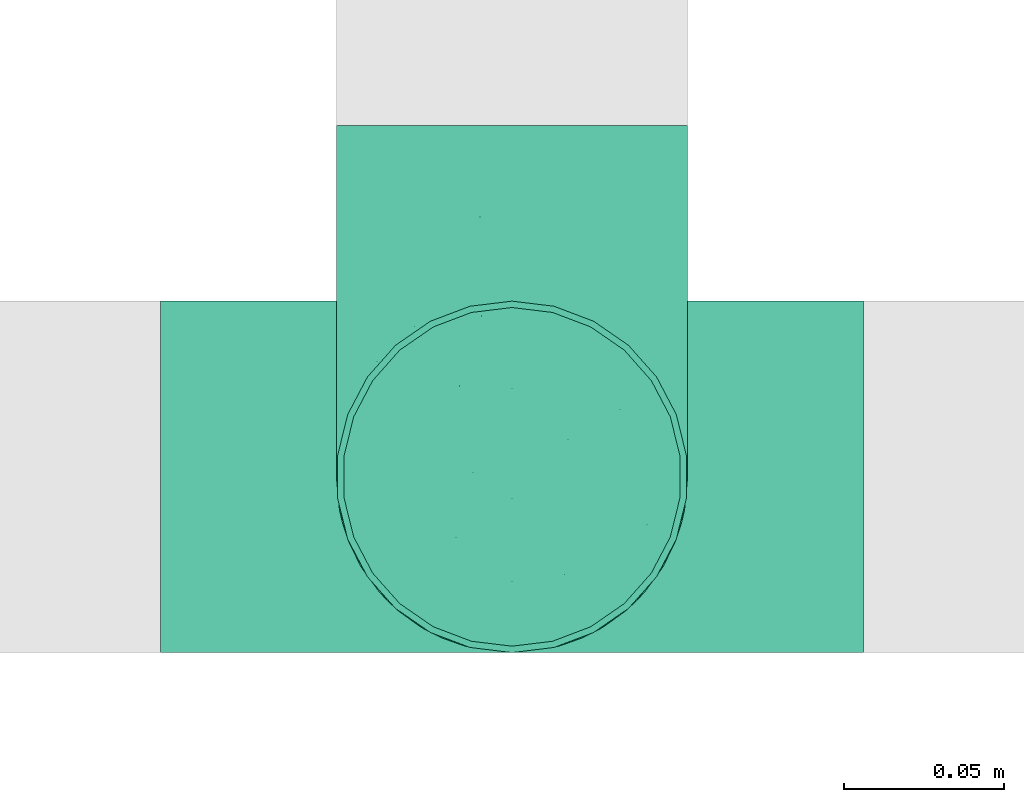
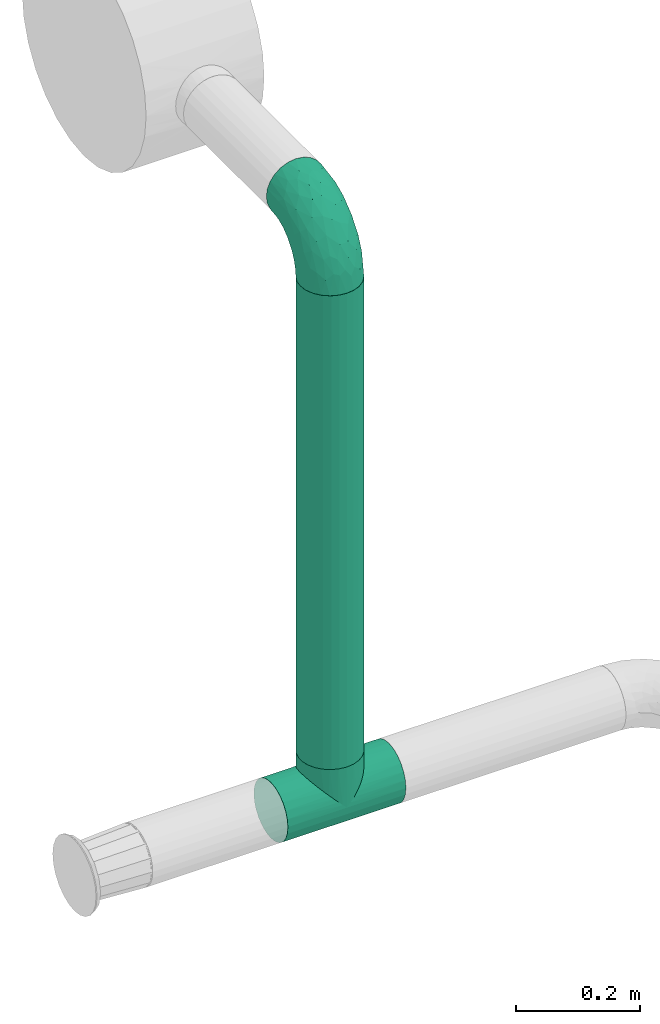
# One storey, part 85 of 103: 2 flow fittings, 1 flow segment.
"""IFC2X3 building model written with IfcOpenShell, lengths in millimetres."""

from ifc_helpers import new_model, entity, si_unit, converted_unit, derived_unit, direction, frame, origin_with_axes, origin_2d_with_axis, place, context, subcontext, project, spatial, hollow_circle, extrude, open_shell, surface_model, source, transform, mapped, material, layer, layer_set, layer_usage, type_object, element, save


model = new_model("IFC2X3")

# Units and contexts
model_context = context("Model", 3, precision=1e-05, world=origin_with_axes(), true_north=direction((0.0, 1.0)))
body_context = subcontext(model_context, "Body", "Model", "MODEL_VIEW")
ifc_project = project(units=[si_unit("AREAUNIT", "SQUARE_METRE"), si_unit("VOLUMEUNIT", "CUBIC_METRE", prefix="DECI"), si_unit("TIMEUNIT", "SECOND"), si_unit("THERMODYNAMICTEMPERATUREUNIT", "DEGREE_CELSIUS"), si_unit("PRESSUREUNIT", "PASCAL"), si_unit("MASSUNIT", "GRAM", prefix="KILO"), si_unit("LENGTHUNIT", "METRE", prefix="MILLI"), si_unit("POWERUNIT", "WATT"), si_unit("ELECTRICCURRENTUNIT", "AMPERE"), si_unit("ELECTRICVOLTAGEUNIT", "VOLT"), derived_unit("VOLUMETRICFLOWRATEUNIT", [(si_unit("VOLUMEUNIT", "CUBIC_METRE", prefix="DECI"), 1), (si_unit("TIMEUNIT", "SECOND"), -1)]), derived_unit("LINEARVELOCITYUNIT", [(si_unit("LENGTHUNIT", "METRE"), 1), (si_unit("TIMEUNIT", "SECOND"), -1)]), derived_unit("MASSDENSITYUNIT", [(si_unit("MASSUNIT", "GRAM", prefix="KILO"), 1), (si_unit("VOLUMEUNIT", "CUBIC_METRE"), -1)]), converted_unit("PLANEANGLEUNIT", "DEGREE", entity("IfcRatioMeasure", 0.01745), si_unit("PLANEANGLEUNIT", "RADIAN"), dimensions=[0, 0, 0, 0, 0, 0, 0])], contexts=[model_context])

# Site, building, storey
site_placement = place(None, origin_with_axes())
site = spatial("IfcSite", under=ifc_project, at=site_placement, CompositionType="ELEMENT")
building_placement = place(site_placement, origin_with_axes())
building = spatial("IfcBuilding", under=site, at=building_placement, Name="mc-building", CompositionType="ELEMENT")
storey_placement = place(building_placement, frame((0.0, 0.0, 5900.0), z_axis=(0.0, 0.0, 1.0), x_axis=(1.0, 0.0, 0.0)))
storey = spatial("IfcBuildingStorey", under=building, at=storey_placement, Name="3. Korrus", CompositionType="ELEMENT", Elevation=5900.0)

# Flow fitting
duct_fitting_type_1 = type_object("IfcDuctFittingType", PredefinedType="JUNCTION")
shared_shape_1 = source(origin_with_axes(), body_context, "Body", "SurfaceModel", [
    surface_model("IfcShellBasedSurfaceModel", [(0.0, -80.0, -55.0), (14.23505, -80.0, -53.12592), (-14.23505, -80.0, -53.12592), (-53.12592, -80.0, 14.23505), (-27.5, -80.0, -47.63139), (-47.63139, -80.0, -27.5), (-38.89087, -80.0, -38.89087), (55.0, -80.0, 0.0), (53.12592, -80.0, 14.23505), (38.89087, -80.0, -38.89087), (27.5, -80.0, -47.63139), (53.12592, -80.0, -14.23505), (47.63139, -80.0, -27.5), (-53.12592, -80.0, -14.23505), (-47.63139, -80.0, 27.5), (-38.89087, -80.0, 38.89087), (14.23505, -80.0, 53.12592), (-27.5, -80.0, 47.63139), (-14.23505, -80.0, 53.12592), (47.63139, -80.0, 27.5), (38.89087, -80.0, 38.89087), (27.5, -80.0, 47.63139), (0.0, -80.0, 55.0), (-55.0, -80.0, 0.0), (0.0, 0.0, 55.0), (-7.4066, -7.4066, 54.49901), (-14.74521, -14.74521, 52.98659), (-21.93978, -21.93978, 50.43457), (-28.89905, -28.89905, 46.79578), (-35.50357, -35.50357, 42.00591), (-41.58668, -41.58668, 35.99373), (-46.92319, -46.92319, 28.69171), (-51.19777, -51.19777, 20.0945), (-50.37866, -80.0, 20.86752), (-54.01174, -54.01174, 10.37938), (-55.0, -55.0, 0.0), (-54.06296, -80.0, 7.11752), (-54.01174, -54.01174, -10.37938), (-51.19777, -51.19777, -20.0945), (-54.06296, -80.0, -7.11752), (-46.92319, -46.92319, -28.69171), (-41.58668, -41.58668, -35.99373), (-50.37866, -80.0, -20.86752), (-35.50357, -35.50357, -42.00591), (-21.93978, -21.93978, -50.43457), (-14.74521, -14.74521, -52.98659), (-7.4066, -7.4066, -54.49901), (0.0, 0.0, -55.0), (-28.89905, -28.89905, -46.79578), (7.4066, -7.4066, -54.49901), (14.74521, -14.74521, -52.98659), (21.93978, -21.93978, -50.43457), (28.89905, -28.89905, -46.79578), (35.50357, -35.50357, -42.00591), (41.58668, -41.58668, -35.99373), (46.92319, -46.92319, -28.69171), (51.19777, -51.19777, -20.0945), (50.37866, -80.0, -20.86752), (54.01174, -54.01174, -10.37938), (55.0, -55.0, 0.0), (54.06296, -80.0, -7.11752), (54.01174, -54.01174, 10.37938), (51.19777, -51.19777, 20.0945), (54.06296, -80.0, 7.11752), (46.92319, -46.92319, 28.69171), (41.58668, -41.58668, 35.99373), (50.37866, -80.0, 20.86752), (35.50357, -35.50357, 42.00591), (21.93978, -21.93978, 50.43457), (14.74521, -14.74521, 52.98659), (7.4066, -7.4066, 54.49901), (28.89905, -28.89905, 46.79578), (-110.0, 0.0, -55.0), (-110.0, -14.23505, -53.12592), (-110.0, 14.23505, -53.12592), (-110.0, 53.12592, 14.23505), (-110.0, 27.5, -47.63139), (-110.0, 47.63139, -27.5), (-110.0, 38.89087, -38.89087), (-110.0, -55.0, 0.0), (-110.0, -53.12592, 14.23505), (-110.0, -38.89087, -38.89087), (-110.0, -27.5, -47.63139), (-110.0, -53.12592, -14.23505), (-110.0, -47.63139, -27.5), (-110.0, 53.12592, -14.23505), (-110.0, 47.63139, 27.5), (-110.0, 38.89087, 38.89087), (-110.0, -14.23505, 53.12592), (-110.0, 27.5, 47.63139), (-110.0, 14.23505, 53.12592), (-110.0, -47.63139, 27.5), (-110.0, -38.89087, 38.89087), (-110.0, -27.5, 47.63139), (-110.0, 0.0, 55.0), (-110.0, 55.0, 0.0), (110.0, 55.0, 0.0), (110.0, 0.0, -55.0), (110.0, 14.23505, -53.12592), (110.0, 27.5, -47.63139), (110.0, 38.89087, -38.89087), (110.0, 47.63139, -27.5), (110.0, -38.89087, -38.89087), (110.0, -53.12592, 14.23505), (110.0, -27.5, -47.63139), (110.0, -14.23505, -53.12592), (110.0, -47.63139, -27.5), (110.0, -53.12592, -14.23505), (110.0, -55.0, 0.0), (110.0, 53.12592, -14.23505), (110.0, 53.12592, 14.23505), (110.0, 47.63139, 27.5), (110.0, 38.89087, 38.89087), (110.0, 0.0, 55.0), (110.0, 27.5, 47.63139), (110.0, 14.23505, 53.12592), (110.0, -47.63139, 27.5), (110.0, -38.89087, 38.89087), (110.0, -27.5, 47.63139), (110.0, -14.23505, 53.12592)], [open_shell([[[0, 1, 2]], [[2, 3, 4]], [[5, 6, 3]], [[6, 4, 3]], [[2, 7, 8]], [[9, 7, 10]], [[1, 10, 7]], [[11, 7, 12]], [[9, 12, 7]], [[7, 2, 1]], [[5, 3, 13]], [[2, 14, 3]], [[2, 15, 14]], [[2, 16, 17]], [[17, 15, 2]], [[16, 18, 17]], [[2, 8, 19]], [[2, 19, 20]], [[2, 20, 21]], [[16, 2, 21]], [[16, 22, 18]], [[23, 13, 3]], [[24, 25, 22]], [[26, 27, 18]], [[25, 26, 18]], [[22, 25, 18]], [[17, 28, 29]], [[17, 18, 27]], [[17, 29, 15]], [[28, 17, 27]], [[30, 31, 14]], [[32, 3, 33]], [[32, 34, 3]], [[35, 36, 34]], [[31, 32, 14]], [[15, 30, 14]], [[34, 36, 3]], [[33, 14, 32]], [[36, 35, 23]], [[30, 15, 29]], [[37, 38, 13]], [[37, 13, 39]], [[40, 41, 5]], [[38, 5, 42]], [[38, 40, 5]], [[37, 39, 35]], [[35, 39, 23]], [[13, 38, 42]], [[41, 6, 5]], [[41, 43, 6]], [[44, 45, 2]], [[46, 47, 0]], [[45, 46, 2]], [[43, 48, 4]], [[44, 4, 48]], [[44, 2, 4]], [[46, 0, 2]], [[43, 4, 6]], [[47, 49, 0]], [[50, 51, 1]], [[49, 50, 1]], [[0, 49, 1]], [[10, 52, 53]], [[10, 1, 51]], [[10, 53, 9]], [[52, 10, 51]], [[54, 55, 12]], [[56, 11, 57]], [[56, 58, 11]], [[59, 60, 58]], [[55, 56, 12]], [[9, 54, 12]], [[58, 60, 11]], [[57, 12, 56]], [[60, 59, 7]], [[54, 9, 53]], [[61, 62, 8]], [[61, 8, 63]], [[64, 65, 19]], [[62, 19, 66]], [[62, 64, 19]], [[61, 63, 59]], [[7, 59, 63]], [[62, 66, 8]], [[65, 20, 19]], [[65, 67, 20]], [[68, 69, 16]], [[70, 24, 22]], [[69, 70, 16]], [[67, 71, 21]], [[68, 21, 71]], [[68, 16, 21]], [[70, 22, 16]], [[67, 21, 20]], [[72, 73, 74]], [[74, 75, 76]], [[77, 78, 75]], [[76, 75, 78]], [[74, 79, 80]], [[81, 79, 82]], [[73, 82, 79]], [[83, 79, 84]], [[81, 84, 79]], [[79, 74, 73]], [[77, 75, 85]], [[74, 86, 75]], [[74, 87, 86]], [[74, 88, 89]], [[89, 87, 74]], [[88, 90, 89]], [[74, 91, 92]], [[91, 74, 80]], [[92, 93, 74]], [[74, 93, 88]], [[88, 94, 90]], [[95, 85, 75]], [[96, 97, 98]], [[99, 96, 98]], [[96, 100, 101]], [[100, 96, 99]], [[102, 97, 103]], [[97, 102, 104]], [[104, 105, 97]], [[102, 103, 106]], [[106, 103, 107]], [[108, 107, 103]], [[109, 96, 101]], [[110, 111, 97]], [[97, 111, 112]], [[113, 97, 114]], [[97, 112, 114]], [[113, 114, 115]], [[116, 103, 97]], [[117, 116, 97]], [[118, 117, 97]], [[119, 118, 97]], [[119, 97, 113]], [[96, 110, 97]], [[24, 113, 115]], [[89, 115, 114]], [[94, 24, 90]], [[90, 24, 115]], [[115, 89, 90]], [[114, 87, 89]], [[86, 112, 111]], [[75, 111, 110]], [[95, 110, 96]], [[87, 112, 86]], [[86, 111, 75]], [[110, 95, 75]], [[112, 87, 114]], [[85, 96, 109]], [[77, 109, 101]], [[95, 96, 85]], [[85, 109, 77]], [[101, 78, 77]], [[101, 100, 78]], [[76, 100, 99]], [[74, 99, 98]], [[47, 98, 97]], [[76, 99, 74]], [[47, 72, 74]], [[98, 47, 74]], [[100, 76, 78]], [[47, 46, 72]], [[45, 44, 73]], [[46, 45, 73]], [[72, 46, 73]], [[82, 48, 43]], [[82, 73, 44]], [[82, 43, 81]], [[48, 82, 44]], [[41, 40, 84]], [[38, 37, 83]], [[40, 38, 84]], [[81, 41, 84]], [[37, 79, 83]], [[83, 84, 38]], [[79, 37, 35]], [[41, 81, 43]], [[49, 97, 105]], [[105, 104, 51]], [[53, 104, 102]], [[53, 52, 104]], [[49, 47, 97]], [[51, 50, 105]], [[52, 51, 104]], [[49, 105, 50]], [[54, 102, 106]], [[56, 106, 107]], [[58, 107, 108]], [[55, 54, 106]], [[58, 56, 107]], [[59, 58, 108]], [[55, 106, 56]], [[102, 54, 53]], [[34, 32, 80]], [[31, 30, 91]], [[32, 31, 91]], [[35, 34, 79]], [[80, 79, 34]], [[32, 91, 80]], [[30, 92, 91]], [[30, 29, 92]], [[27, 26, 88]], [[25, 24, 94]], [[26, 25, 88]], [[29, 28, 93]], [[27, 93, 28]], [[27, 88, 93]], [[25, 94, 88]], [[29, 93, 92]], [[61, 108, 103]], [[62, 103, 116]], [[65, 116, 117]], [[61, 59, 108]], [[64, 62, 116]], [[65, 64, 116]], [[61, 103, 62]], [[117, 67, 65]], [[71, 67, 118]], [[118, 67, 117]], [[68, 118, 119]], [[70, 119, 113]], [[68, 71, 118]], [[70, 69, 119]], [[24, 70, 113]], [[68, 119, 69]]])]),
])
flow_fitting_1_placement = place(storey_placement, frame((32476.59509, 9477.62755, 2345.0), z_axis=(0.0, 1.0, 0.0), x_axis=(1.0, 0.0, 0.0)))
element("IfcFlowFitting", 1, at=flow_fitting_1_placement, inside=storey, type_object=duct_fitting_type_1, context=body_context, shape_type="MappedRepresentation", body=[
    mapped(shared_shape_1, transform((0.0, 0.0, 0.0), scale=1.0)),
])

# Flow segment
ifc_material = material(Name="FZ1")
ifc_layer = layer(ifc_material, 0.0)
ifc_layer_set = layer_set([ifc_layer], Name="FZ1")
ifc_layer_usage = layer_usage(ifc_layer_set, "AXIS1", "POSITIVE", 0.0)
duct_segment_type = type_object("IfcDuctSegmentType", PredefinedType="RIGIDSEGMENT")
shared_shape_2 = source(origin_with_axes(), body_context, "Body", "SweptSolid", [
    extrude(hollow_circle(Radius=55.0, WallThickness=2.0, at=origin_2d_with_axis()), frame((0.0, 0.0, 0.0), z_axis=(1.0, 0.0, 0.0), x_axis=(0.0, 1.0, 0.0)), (0.0, 0.0, 1.0), 933.0),
])
flow_segment_placement = place(storey_placement, frame((32476.59509, 9477.62755, 2425.0), z_axis=(1.0, 0.0, 0.0), x_axis=(0.0, 0.0, 1.0)))
element("IfcFlowSegment", 2, at=flow_segment_placement, inside=storey, type_object=duct_segment_type, material=ifc_layer_usage, context=body_context, shape_type="MappedRepresentation", body=[
    mapped(shared_shape_2, transform((0.0, 0.0, 0.0), scale=1.0)),
])

# Flow fitting
duct_fitting_type_2 = type_object("IfcDuctFittingType", Name="BU", PredefinedType="BEND")
shared_shape_3 = source(origin_with_axes(), body_context, "Body", "SurfaceModel", [
    surface_model("IfcShellBasedSurfaceModel", [(-110.0, 0.0, -55.0), (-110.0, -14.23505, -53.12592), (-110.0, 14.23505, -53.12592), (-110.0, 53.12592, 14.23505), (-110.0, 27.5, -47.63139), (-110.0, 38.89087, -38.89087), (-110.0, -55.0, 0.0), (-110.0, -53.12592, 14.23505), (-110.0, -38.89087, -38.89087), (-110.0, -27.5, -47.63139), (-110.0, -53.12592, -14.23505), (-110.0, -47.63139, -27.5), (-110.0, -14.23505, 53.12592), (-110.0, 14.23505, 53.12592), (-110.0, 27.5, 47.63139), (-110.0, -47.63139, 27.5), (-110.0, -38.89087, 38.89087), (-110.0, -27.5, 47.63139), (-110.0, 0.0, 55.0), (-110.0, 55.0, 0.0), (-110.0, 53.12592, -14.23505), (-110.0, 47.63139, -27.5), (-110.0, 47.63139, 27.5), (-110.0, 38.89087, 38.89087), (-14.23505, 110.0, -53.12592), (-55.0, 110.0, 0.0), (0.0, 110.0, -55.0), (-27.5, 110.0, -47.63139), (-38.89087, 110.0, -38.89087), (-47.63139, 110.0, -27.5), (38.89087, 110.0, -38.89087), (53.12592, 110.0, 14.23505), (27.5, 110.0, -47.63139), (14.23505, 110.0, -53.12592), (47.63139, 110.0, -27.5), (53.12592, 110.0, -14.23505), (55.0, 110.0, 0.0), (-53.12592, 110.0, -14.23505), (-53.12592, 110.0, 14.23505), (-47.63139, 110.0, 27.5), (-38.89087, 110.0, 38.89087), (-27.5, 110.0, 47.63139), (0.0, 110.0, 55.0), (-14.23505, 110.0, 53.12592), (38.89087, 110.0, 38.89087), (47.63139, 110.0, 27.5), (27.5, 110.0, 47.63139), (14.23505, 110.0, 53.12592), (-64.21732, 48.68956, 43.63444), (-76.6405, 38.18013, 45.55988), (-60.44912, 32.56953, 51.94617), (-76.00813, 5.38378, 55.0), (-90.15553, 11.94394, 54.09138), (-78.5998, 26.77405, 50.81338), (-70.18771, 18.55163, 54.03432), (-75.55424, 54.2118, 32.41257), (-93.27622, 45.77614, 33.48188), (-96.12334, 22.13664, 50.81337), (-21.00813, 45.34362, 55.0), (-18.36258, 70.48427, 54.04484), (-32.04182, 59.64019, 52.24446), (-63.88653, 74.77858, 17.99134), (-74.66383, 63.08407, 19.92123), (-63.60674, 66.07878, 29.97482), (-99.597, 52.72185, 18.52927), (-93.11138, 56.59448, 10.50359), (-98.21577, 57.34403, 0.0), (-53.42855, 92.60092, 21.04759), (-88.54852, 54.8376, 21.04759), (-11.86161, 90.23965, 54.10313), (-5.38378, 76.00813, 55.0), (-57.34403, 98.21577, 0.0), (-56.64619, 93.12774, 10.22088), (-45.34362, 21.00813, 55.0), (-44.60838, 44.60838, 52.13415), (-92.68484, 35.46673, 43.63443), (-22.25266, 95.40765, 50.81337), (-35.97783, 90.61597, 43.63443), (-43.70931, 69.58671, 44.47149), (-27.23711, 77.39884, 50.81337), (-57.2828, 79.3123, 24.9774), (-58.67786, 84.31125, 16.04456), (-82.93277, 60.36161, 12.91784), (-49.88337, 54.51816, 47.224), (-74.57753, 66.83759, 9.55742), (-45.35812, 94.97281, 33.48188), (-59.18663, 88.95241, 0.0), (-51.517, 78.6292, 33.48188), (-65.14788, 80.03077, 0.0), (-56.45322, 62.06476, 39.63545), (-88.95241, 59.18663, 0.0), (-71.10913, 71.10913, 0.0), (-80.03077, 65.14788, 0.0), (-94.9309, 45.36788, -33.48188), (-93.11358, 56.60141, -10.46614), (-99.64997, 52.79499, -18.30015), (-90.20425, 36.08686, -43.63443), (-79.99933, 46.56772, -37.92748), (-76.00813, 5.38378, -55.0), (-72.75364, 19.68651, -53.60527), (-45.34362, 21.00813, -55.0), (-21.91957, 65.12078, -53.85897), (-5.38378, 76.00813, -55.0), (-21.00813, 45.34362, -55.0), (-35.41876, 92.89265, -43.63443), (-91.10309, 11.02766, -54.21832), (-45.77614, 93.27622, -33.48188), (-90.50474, 23.21022, -50.81337), (-70.92854, 33.31794, -49.51754), (-78.52933, 63.35627, -11.73997), (-24.91508, 84.05606, -50.81337), (-88.78941, 54.74452, -21.04759), (-69.59921, 57.34866, -33.48187), (-73.36422, 62.46673, -22.94182), (-63.49062, 67.59111, -28.46929), (-56.59448, 93.11138, -10.50359), (-54.8376, 88.54852, -21.04759), (-54.10679, 75.85581, -32.31867), (-57.75956, 31.09612, -52.80882), (-52.72185, 99.597, -18.52927), (-12.62913, 89.46304, -53.99097), (-34.46825, 66.46123, -50.04329), (-43.9837, 43.9837, -52.42279), (-65.78527, 72.58348, -17.68796), (-70.34468, 43.65295, -44.21951), (-57.47001, 51.99467, -44.91465), (-60.72547, 82.29174, -12.88567), (-42.34915, 74.24548, -43.63444), (-57.25194, 63.5016, -38.08211), (-80.95344, 53.56991, -29.32027), (-52.32891, 4.55257, -54.0482), (32.52942, 47.13398, -30.48571), (14.88266, 20.92917, -33.7947), (14.95561, 36.05775, -42.26543), (30.24048, 70.09027, -41.7461), (19.3559, 65.35825, -48.00507), (-70.35075, -46.44478, -19.5952), (-47.13398, -32.52942, -30.48571), (-28.49299, -30.5778, -16.4009), (-4.55257, 52.32891, -54.0482), (-22.4954, 22.4954, -53.25347), (-75.47368, -11.22546, -52.60718), (-81.32209, -51.5606, -9.98467), (-80.81763, -41.84862, -32.14655), (-70.09027, -30.24048, -41.7461), (-36.05774, -14.95561, -42.26543), (-9.15831, -10.852, -27.8997), (-65.35825, -19.3559, -48.00507), (11.22546, 75.47368, -52.60718), (3.94376, 43.9333, -50.53315), (-13.39742, 13.39743, -48.13058), (-43.9333, -3.94376, -50.53315), (49.37776, 67.29486, 0.0), (41.8609, 47.82256, -9.92641), (50.20582, 74.51695, -9.9731), (18.93131, 11.7156, -17.56239), (-27.5, -32.89419, 0.0), (-1.23348, -12.25375, -12.18106), (41.84862, 80.81763, -32.14655), (35.70604, 41.31408, -20.38235), (46.44478, 70.35075, -19.5952), (32.89419, 27.5, 0.0), (6.67262, -6.67262, 0.0), (-67.29486, -49.37776, 0.0), (-50.36265, -42.95545, -9.51562), (-5.47251, 5.47251, -39.92906), (-70.35075, -46.44478, 19.5952), (-74.51695, -50.20582, 9.9731), (-41.31407, -35.70604, 20.38235), (-47.13398, -32.52942, 30.48571), (-80.81763, -41.84862, 32.14655), (-4.55257, 52.32891, 54.0482), (11.22546, 75.47368, 52.60718), (-43.9333, -3.94376, 50.53315), (-65.35825, -19.3559, 48.00507), (-36.05774, -14.95561, 42.26543), (-70.09027, -30.24048, 41.7461), (-11.7156, -18.93131, 17.56239), (30.5778, 28.49299, 16.4009), (12.25375, 1.23348, 12.18106), (51.5606, 81.32209, 9.98467), (42.95545, 50.36265, 9.51562), (-75.47368, -11.22546, 52.60718), (-52.32891, 4.55257, 54.0482), (3.94376, 43.9333, 50.53315), (-22.4954, 22.4954, 53.25347), (-13.39742, 13.39743, 48.13058), (10.852, 9.15831, 27.8997), (-20.92916, -14.88266, 33.79469), (-47.82256, -41.8609, 9.92641), (32.52942, 47.13398, 30.48571), (46.44478, 70.35075, 19.5952), (41.84862, 80.81763, 32.14655), (30.24048, 70.09027, 41.7461), (19.3559, 65.35825, 48.00507), (14.95561, 36.05775, 42.26543), (-5.47251, 5.47251, 39.92906)], [open_shell([[[0, 1, 2]], [[2, 3, 4]], [[4, 3, 5]], [[2, 6, 7]], [[8, 6, 9]], [[1, 9, 6]], [[10, 6, 11]], [[8, 11, 6]], [[6, 2, 1]], [[12, 13, 14]], [[15, 2, 7]], [[16, 17, 2]], [[2, 17, 12]], [[12, 18, 13]], [[19, 20, 3]], [[5, 3, 21]], [[20, 21, 3]], [[22, 3, 2]], [[23, 22, 2]], [[12, 14, 2]], [[2, 14, 23]], [[15, 16, 2]], [[24, 25, 26]], [[27, 25, 24]], [[25, 28, 29]], [[28, 25, 27]], [[30, 26, 31]], [[26, 30, 32]], [[32, 33, 26]], [[34, 31, 35]], [[31, 34, 30]], [[35, 31, 36]], [[29, 37, 25]], [[38, 39, 26]], [[39, 40, 26]], [[41, 42, 40]], [[42, 26, 40]], [[42, 41, 43]], [[26, 44, 45]], [[31, 26, 45]], [[26, 46, 44]], [[47, 46, 26]], [[42, 47, 26]], [[25, 38, 26]], [[48, 49, 50]], [[18, 51, 52]], [[53, 54, 50]], [[55, 56, 49]], [[56, 22, 23]], [[13, 57, 14]], [[58, 59, 60]], [[61, 62, 63]], [[3, 64, 65]], [[53, 52, 54]], [[3, 65, 66]], [[67, 39, 38]], [[56, 68, 64]], [[65, 64, 68]], [[69, 59, 70]], [[38, 71, 72]], [[73, 58, 74]], [[75, 49, 56]], [[76, 69, 43]], [[53, 57, 52]], [[77, 78, 79]], [[41, 76, 43]], [[43, 69, 42]], [[55, 68, 56]], [[23, 14, 75]], [[76, 77, 79]], [[80, 67, 81]], [[62, 82, 68]], [[60, 78, 83]], [[62, 84, 82]], [[85, 77, 40]], [[81, 67, 72]], [[86, 72, 71]], [[87, 85, 67]], [[61, 81, 88]], [[77, 41, 40]], [[78, 77, 87]], [[23, 75, 56]], [[83, 89, 48]], [[85, 40, 39]], [[62, 68, 55]], [[89, 87, 63]], [[83, 48, 50]], [[57, 75, 14]], [[49, 75, 53]], [[67, 85, 39]], [[87, 77, 85]], [[63, 62, 55]], [[89, 55, 48]], [[80, 63, 87]], [[66, 65, 90]], [[66, 19, 3]], [[84, 91, 92]], [[92, 90, 82]], [[65, 82, 90]], [[61, 84, 62]], [[92, 82, 84]], [[68, 82, 65]], [[3, 22, 64]], [[56, 64, 22]], [[38, 25, 71]], [[81, 72, 86]], [[38, 72, 67]], [[91, 61, 88]], [[80, 81, 61]], [[63, 80, 61]], [[67, 80, 87]], [[77, 76, 41]], [[79, 59, 69]], [[79, 69, 76]], [[42, 69, 70]], [[60, 59, 79]], [[58, 70, 59]], [[78, 60, 79]], [[58, 60, 74]], [[52, 57, 13]], [[75, 57, 53]], [[18, 52, 13]], [[52, 51, 54]], [[51, 73, 54]], [[50, 73, 74]], [[73, 50, 54]], [[50, 74, 83]], [[60, 83, 74]], [[89, 83, 78]], [[87, 89, 78]], [[55, 89, 63]], [[50, 49, 53]], [[55, 49, 48]], [[81, 86, 88]], [[91, 84, 61]], [[5, 21, 93]], [[90, 94, 66]], [[20, 94, 95]], [[96, 93, 97]], [[98, 99, 100]], [[96, 4, 5]], [[101, 102, 103]], [[28, 27, 104]], [[2, 105, 0]], [[104, 106, 28]], [[99, 105, 107]], [[108, 107, 96]], [[90, 109, 94]], [[107, 2, 4]], [[20, 66, 94]], [[27, 24, 110]], [[109, 111, 94]], [[112, 113, 114]], [[37, 115, 71]], [[116, 106, 117]], [[99, 118, 100]], [[116, 115, 119]], [[37, 119, 115]], [[24, 120, 110]], [[121, 110, 101]], [[119, 106, 116]], [[101, 110, 120]], [[122, 103, 100]], [[117, 123, 116]], [[124, 125, 108]], [[115, 116, 126]], [[106, 29, 28]], [[26, 102, 120]], [[127, 104, 110]], [[97, 124, 96]], [[125, 122, 118]], [[128, 127, 125]], [[96, 5, 93]], [[115, 126, 86]], [[117, 106, 127]], [[111, 113, 129]], [[95, 93, 21]], [[97, 129, 112]], [[110, 104, 27]], [[106, 104, 127]], [[96, 107, 4]], [[99, 107, 108]], [[99, 108, 118]], [[105, 99, 98]], [[112, 114, 128]], [[121, 125, 127]], [[20, 19, 66]], [[109, 90, 92]], [[94, 111, 95]], [[91, 123, 109]], [[129, 113, 112]], [[93, 95, 111]], [[21, 20, 95]], [[71, 115, 86]], [[71, 25, 37]], [[123, 91, 88]], [[126, 116, 123]], [[123, 88, 126]], [[86, 126, 88]], [[37, 29, 119]], [[106, 119, 29]], [[129, 93, 111]], [[124, 112, 125]], [[0, 105, 98]], [[107, 105, 2]], [[125, 118, 108]], [[100, 118, 122]], [[93, 129, 97]], [[113, 111, 109]], [[109, 123, 113]], [[114, 123, 117]], [[123, 114, 113]], [[128, 114, 117]], [[127, 128, 117]], [[112, 128, 125]], [[103, 122, 101]], [[110, 121, 127]], [[101, 122, 121]], [[125, 121, 122]], [[26, 120, 24]], [[101, 120, 102]], [[96, 124, 108]], [[92, 91, 109]], [[112, 124, 97]], [[100, 130, 98]], [[131, 132, 133]], [[32, 134, 135]], [[136, 137, 138]], [[139, 140, 103]], [[98, 141, 0]], [[142, 10, 136]], [[143, 144, 137]], [[6, 10, 142]], [[137, 145, 146]], [[144, 147, 145]], [[143, 136, 11]], [[11, 136, 10]], [[8, 143, 11]], [[148, 149, 139]], [[8, 9, 144]], [[9, 1, 147]], [[130, 141, 98]], [[103, 140, 100]], [[148, 135, 149]], [[150, 151, 140]], [[152, 153, 154]], [[130, 140, 151]], [[148, 26, 33]], [[147, 1, 141]], [[155, 146, 132]], [[156, 138, 157]], [[134, 30, 158]], [[150, 140, 149]], [[158, 30, 34]], [[30, 134, 32]], [[153, 159, 160]], [[131, 160, 159]], [[144, 145, 137]], [[36, 152, 154]], [[146, 138, 137]], [[155, 161, 162]], [[158, 160, 131]], [[133, 149, 135]], [[156, 163, 164]], [[163, 142, 164]], [[139, 103, 102]], [[153, 152, 161]], [[34, 35, 160]], [[162, 157, 155]], [[132, 165, 133]], [[157, 146, 155]], [[140, 130, 100]], [[141, 130, 151]], [[141, 151, 147]], [[141, 1, 0]], [[102, 26, 148]], [[140, 139, 149]], [[102, 148, 139]], [[135, 33, 32]], [[151, 150, 145]], [[9, 147, 144]], [[151, 145, 147]], [[145, 165, 146]], [[135, 148, 33]], [[133, 135, 134]], [[131, 133, 134]], [[133, 165, 150]], [[133, 150, 149]], [[145, 150, 165]], [[132, 131, 159]], [[146, 165, 132]], [[160, 158, 34]], [[134, 158, 131]], [[144, 143, 8]], [[136, 143, 137]], [[155, 153, 161]], [[154, 153, 160]], [[153, 155, 159]], [[132, 159, 155]], [[160, 35, 154]], [[36, 154, 35]], [[164, 136, 138]], [[6, 142, 163]], [[136, 164, 142]], [[156, 164, 138]], [[156, 157, 162]], [[146, 157, 138]], [[15, 7, 166]], [[6, 163, 167]], [[168, 169, 166]], [[166, 169, 170]], [[171, 172, 70]], [[173, 174, 175]], [[17, 176, 174]], [[177, 156, 162]], [[176, 16, 170]], [[170, 16, 15]], [[161, 178, 179]], [[152, 180, 181]], [[182, 173, 183]], [[18, 12, 182]], [[184, 185, 186]], [[183, 185, 73]], [[183, 73, 51]], [[177, 187, 188]], [[189, 168, 166]], [[187, 178, 190]], [[16, 176, 17]], [[161, 152, 181]], [[45, 191, 31]], [[45, 44, 192]], [[192, 191, 45]], [[180, 36, 31]], [[193, 194, 195]], [[46, 47, 194]], [[193, 195, 190]], [[193, 44, 46]], [[172, 42, 70]], [[185, 58, 73]], [[189, 163, 156]], [[163, 189, 167]], [[70, 58, 171]], [[184, 171, 185]], [[169, 188, 175]], [[180, 31, 191]], [[192, 193, 190]], [[191, 190, 178]], [[182, 174, 173]], [[194, 47, 172]], [[190, 195, 187]], [[186, 185, 173]], [[162, 179, 177]], [[188, 196, 175]], [[179, 187, 177]], [[185, 171, 58]], [[172, 171, 184]], [[172, 184, 194]], [[172, 47, 42]], [[51, 18, 182]], [[185, 183, 173]], [[51, 182, 183]], [[174, 12, 17]], [[184, 186, 195]], [[46, 194, 193]], [[184, 195, 194]], [[195, 196, 187]], [[174, 182, 12]], [[175, 174, 176]], [[169, 175, 176]], [[175, 196, 186]], [[175, 186, 173]], [[195, 186, 196]], [[188, 169, 168]], [[187, 196, 188]], [[166, 170, 15]], [[176, 170, 169]], [[193, 192, 44]], [[191, 192, 190]], [[177, 189, 156]], [[167, 189, 166]], [[189, 177, 168]], [[188, 168, 177]], [[166, 7, 167]], [[6, 167, 7]], [[181, 191, 178]], [[36, 180, 152]], [[191, 181, 180]], [[161, 181, 178]], [[161, 179, 162]], [[187, 179, 178]]])]),
])
flow_fitting_2_placement = place(storey_placement, frame((32476.59509, 9477.62755, 3468.0), z_axis=(-1.0, 0.0, 0.0), x_axis=(0.0, 0.0, 1.0)))
element("IfcFlowFitting", 3, at=flow_fitting_2_placement, inside=storey, type_object=duct_fitting_type_2, Name="BU", context=body_context, shape_type="MappedRepresentation", body=[
    mapped(shared_shape_3, transform((0.0, 0.0, 0.0), scale=1.0)),
])

save(model, "model.ifc")
